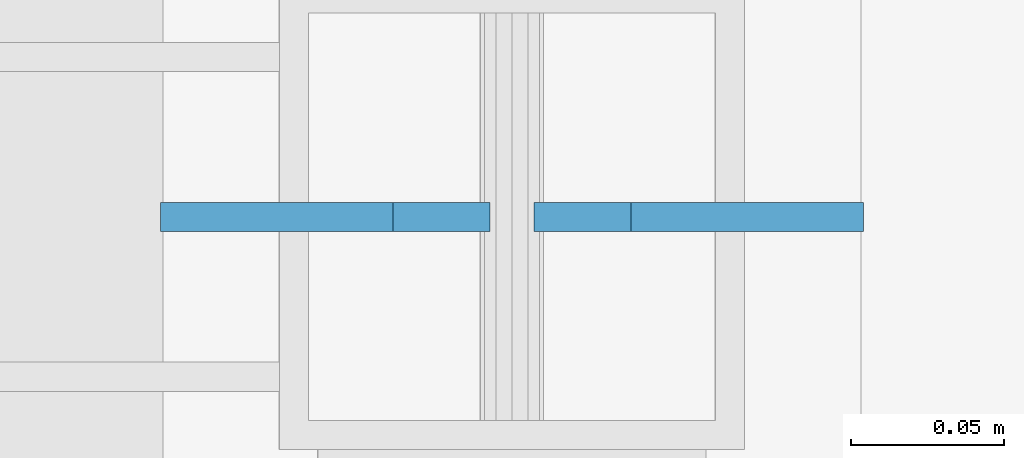
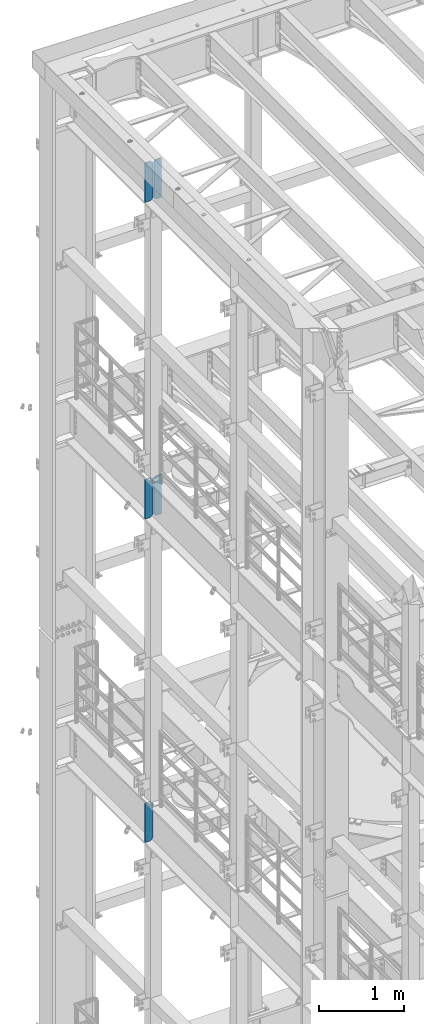
# One storey, part 1756 of 1876: 5 plates, 3 elements without a shape of their own.
"""IFC2X3 building model written with IfcOpenShell, lengths in millimetres."""

from ifc_helpers import new_model, si_unit, frame, origin_with_axes, place, context, subcontext, project, spatial, faceted_brep, material, type_object, element, aggregate, save


model = new_model("IFC2X3")

# Units and contexts
model_context = context("Model", 3, precision=1e-05, world=origin_with_axes())
body_context = subcontext(model_context, "Body", "Model", "MODEL_VIEW")
ifc_project = project(units=[si_unit("LENGTHUNIT", "METRE", prefix="MILLI"), si_unit("AREAUNIT", "SQUARE_METRE"), si_unit("VOLUMEUNIT", "CUBIC_METRE"), si_unit("MASSUNIT", "GRAM", prefix="KILO"), si_unit("TIMEUNIT", "SECOND"), si_unit("PLANEANGLEUNIT", "RADIAN"), si_unit("SOLIDANGLEUNIT", "STERADIAN"), si_unit("THERMODYNAMICTEMPERATUREUNIT", "DEGREE_CELSIUS"), si_unit("LUMINOUSINTENSITYUNIT", "LUMEN")], contexts=[model_context])

# Site, building, storey
site_placement = place(None, origin_with_axes())
site = spatial("IfcSite", under=ifc_project, at=site_placement, CompositionType="ELEMENT")
building_placement = place(site_placement, origin_with_axes())
building = spatial("IfcBuilding", under=site, at=building_placement, Name="Undefined", CompositionType="ELEMENT")
storey_placement = place(building_placement, origin_with_axes())
storey = spatial("IfcBuildingStorey", under=building, at=storey_placement, Name="Undefined", CompositionType="ELEMENT", Elevation=0.0)

# Assembly, plates
assembly_1_placement = place(storey_placement, origin_with_axes())
assembly_1 = element("IfcElementAssembly", 1, at=assembly_1_placement, inside=storey, Name="BEAM", AssemblyPlace="NOTDEFINED", PredefinedType="RIGID_FRAME")
ifc_material = material(Name="STEEL/A36")
plate_type = type_object("IfcPlateType", PredefinedType="NOTDEFINED")
plate_1_placement = place(assembly_1_placement, frame((115.093750395763, 11683.9999999841, 21958.3), z_axis=(0.0, 0.0, 1.0), x_axis=(-1.0, 0.0, 0.0)))
plate_1 = element("IfcPlate", 2, at=plate_1_placement, type_object=plate_type, material=ifc_material, Name="PLATE", context=body_context, shape_type="Brep", body=[
    faceted_brep([(0.0, -4.76249999999982, 0.0), (0.0, -4.76249999999982, 571.5), (0.0, 4.76249999999982, 571.5), (0.0, 4.76249999999982, 0.0), (76.1999969482422, -4.76249999999982, 571.5), (76.1999969482422, 4.76249999999982, 571.5), (107.949996948242, -4.76249999999982, 539.75), (107.949996948242, 4.76249999999982, 539.75), (107.949996948242, -4.76249999999982, 31.75), (107.949996948242, 4.76249999999982, 31.75), (76.1999969482422, -4.76250000000073, 0.0), (76.1999969482422, 4.76250000000073, 0.0)], [[[0, 1, 2, 3]], [[1, 4, 5, 2]], [[4, 6, 7, 5]], [[6, 8, 9, 7]], [[8, 10, 11, 9]], [[10, 0, 3, 11]], [[5, 7, 9, 11, 3, 2]], [[10, 8, 6, 4, 1, 0]]]),
])
plate_2_placement = place(assembly_1_placement, frame((-7.14374960423695, 11683.9999999841, 21958.3), z_axis=(0.0, 0.0, 1.0), x_axis=(-1.0, 0.0, 0.0)))
plate_2 = element("IfcPlate", 3, at=plate_2_placement, type_object=plate_type, material=ifc_material, Name="PLATE", context=body_context, shape_type="Brep", body=[
    faceted_brep([(-9.76996261670138e-14, -4.76250000000073, 31.75), (0.0, -4.76249999999982, 539.75), (0.0, 4.76249999999982, 539.75), (-9.76996261670138e-14, 4.76250000000073, 31.75), (31.75, -4.76249999999982, 571.5), (31.75, 4.76249999999982, 571.5), (107.949996948242, -4.76249999999982, 571.5), (107.949996948242, 4.76249999999982, 571.5), (107.950006484985, -4.76250000000073, 0.0), (107.950006484985, 4.76250000000073, 0.0), (31.75, -4.76250000000073, 0.0), (31.75, 4.76250000000073, 0.0)], [[[0, 1, 2, 3]], [[1, 4, 5, 2]], [[4, 6, 7, 5]], [[6, 8, 9, 7]], [[8, 10, 11, 9]], [[10, 0, 3, 11]], [[5, 7, 9, 11, 3, 2]], [[10, 8, 6, 4, 1, 0]]]),
])
aggregate(assembly_1, [plate_1, plate_2])

assembly_2_placement = place(storey_placement, origin_with_axes())
assembly_2 = element("IfcElementAssembly", 4, at=assembly_2_placement, inside=storey, Name="BEAM", AssemblyPlace="NOTDEFINED", PredefinedType="RIGID_FRAME")
plate_3_placement = place(assembly_2_placement, frame((115.093750395763, 11683.9999999841, 17386.3), z_axis=(0.0, 0.0, 1.0), x_axis=(-1.0, 0.0, 0.0)))
plate_3 = element("IfcPlate", 5, at=plate_3_placement, type_object=plate_type, material=ifc_material, Name="PLATE", context=body_context, shape_type="Brep", body=[
    faceted_brep([(0.0, -4.76249999999982, 0.0), (0.0, -4.76249999999982, 571.5), (0.0, 4.76249999999982, 571.5), (0.0, 4.76249999999982, 0.0), (76.1999969482422, -4.76249999999982, 571.5), (76.1999969482422, 4.76249999999982, 571.5), (107.949996948242, -4.76249999999982, 539.75), (107.949996948242, 4.76249999999982, 539.75), (107.949996948242, -4.76249999999982, 31.75), (107.949996948242, 4.76249999999982, 31.75), (76.1999969482422, -4.76250000000073, 0.0), (76.1999969482422, 4.76250000000073, 0.0)], [[[0, 1, 2, 3]], [[1, 4, 5, 2]], [[4, 6, 7, 5]], [[6, 8, 9, 7]], [[8, 10, 11, 9]], [[10, 0, 3, 11]], [[5, 7, 9, 11, 3, 2]], [[10, 8, 6, 4, 1, 0]]]),
])
plate_4_placement = place(assembly_2_placement, frame((-7.14374960423695, 11683.9999999841, 17386.3), z_axis=(0.0, 0.0, 1.0), x_axis=(-1.0, 0.0, 0.0)))
plate_4 = element("IfcPlate", 6, at=plate_4_placement, type_object=plate_type, material=ifc_material, Name="PLATE", context=body_context, shape_type="Brep", body=[
    faceted_brep([(-9.76996261670138e-14, -4.76250000000073, 31.75), (0.0, -4.76249999999982, 539.75), (0.0, 4.76249999999982, 539.75), (-9.76996261670138e-14, 4.76250000000073, 31.75), (31.75, -4.76249999999982, 571.5), (31.75, 4.76249999999982, 571.5), (107.949996948242, -4.76249999999982, 571.5), (107.949996948242, 4.76249999999982, 571.5), (107.950006484985, -4.76250000000073, 0.0), (107.950006484985, 4.76250000000073, 0.0), (31.75, -4.76250000000073, 0.0), (31.75, 4.76250000000073, 0.0)], [[[0, 1, 2, 3]], [[1, 4, 5, 2]], [[4, 6, 7, 5]], [[6, 8, 9, 7]], [[8, 10, 11, 9]], [[10, 0, 3, 11]], [[5, 7, 9, 11, 3, 2]], [[10, 8, 6, 4, 1, 0]]]),
])
aggregate(assembly_2, [plate_3, plate_4])

# Assembly, plate
assembly_3_placement = place(storey_placement, origin_with_axes())
assembly_3 = element("IfcElementAssembly", 7, at=assembly_3_placement, inside=storey, Name="BEAM", AssemblyPlace="NOTDEFINED", PredefinedType="RIGID_FRAME")
plate_5_placement = place(assembly_3_placement, frame((-7.14374960423695, 11683.9999999841, 12712.7), z_axis=(0.0, 0.0, 1.0), x_axis=(-1.0, 0.0, 0.0)))
plate_5 = element("IfcPlate", 8, at=plate_5_placement, type_object=plate_type, material=ifc_material, Name="PLATE", context=body_context, shape_type="Brep", body=[
    faceted_brep([(-9.76996261670138e-14, -4.76250000000073, 31.75), (0.0, -4.76249999999982, 539.75), (0.0, 4.76249999999982, 539.75), (-9.76996261670138e-14, 4.76250000000073, 31.75), (31.75, -4.76249999999982, 571.5), (31.75, 4.76249999999982, 571.5), (107.949996948242, -4.76249999999982, 571.5), (107.949996948242, 4.76249999999982, 571.5), (107.950006484985, -4.76250000000073, 0.0), (107.950006484985, 4.76250000000073, 0.0), (31.75, -4.76250000000073, 0.0), (31.75, 4.76250000000073, 0.0)], [[[0, 1, 2, 3]], [[1, 4, 5, 2]], [[4, 6, 7, 5]], [[6, 8, 9, 7]], [[8, 10, 11, 9]], [[10, 0, 3, 11]], [[5, 7, 9, 11, 3, 2]], [[10, 8, 6, 4, 1, 0]]]),
])
aggregate(assembly_3, [plate_5])

save(model, "model.ifc")
